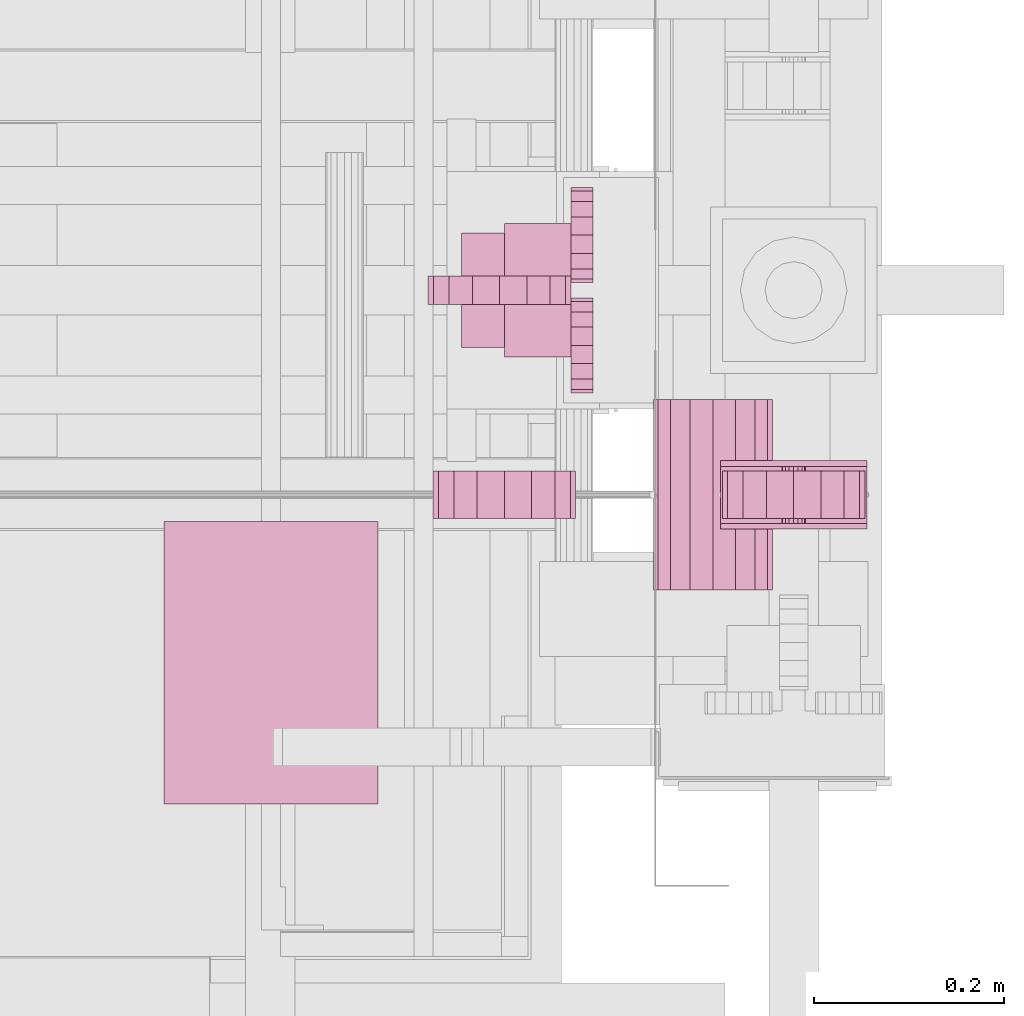
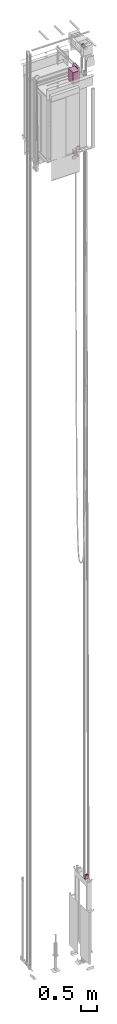
# One storey, part 11 of 13: 7 transport elements.
"""IFC4 building model written with IfcOpenShell, lengths in millimetres."""

from ifc_helpers import new_model, entity, si_unit, converted_unit, frame, origin_with_axes, place, context, subcontext, project, spatial, faceted_brep, element, save


model = new_model("IFC4")

# Units and contexts
context_of_model = context(None, 3, precision=0.01, world=origin_with_axes())
sub_context_1 = subcontext(context_of_model, None, None, "MODEL_VIEW")
sub_context_2 = subcontext(context_of_model, None, None, "MODEL_VIEW")
sub_context_3 = subcontext(context_of_model, None, None, "MODEL_VIEW")
sub_context_4 = subcontext(context_of_model, None, None, "MODEL_VIEW")
sub_context_5 = subcontext(context_of_model, None, None, "MODEL_VIEW")
sub_context_6 = subcontext(context_of_model, None, None, "MODEL_VIEW")
sub_context_7 = subcontext(context_of_model, None, None, "MODEL_VIEW")
ifc_project = project(units=[converted_unit("PLANEANGLEUNIT", "degree", entity("IfcPlaneAngleMeasure", 0.017453292519943), si_unit("PLANEANGLEUNIT", "RADIAN"), dimensions=[0, 0, 0, 0, 0, 0, 0]), si_unit("LENGTHUNIT", "METRE", prefix="MILLI"), si_unit("MASSUNIT", "GRAM", prefix="KILO"), converted_unit("TIMEUNIT", "year", entity("IfcTimeMeasure", 31557600.0), si_unit("TIMEUNIT", "SECOND"), dimensions=[0, 0, 1, 0, 0, 0, 0]), si_unit("THERMODYNAMICTEMPERATUREUNIT", "DEGREE_CELSIUS"), si_unit("AREAUNIT", "SQUARE_METRE"), si_unit("FORCEUNIT", "NEWTON"), si_unit("VOLUMEUNIT", "CUBIC_METRE"), si_unit("PRESSUREUNIT", "PASCAL"), si_unit("SOLIDANGLEUNIT", "STERADIAN")], contexts=[context_of_model])

# Site, building, storey
site = spatial("IfcSite", under=ifc_project)
building = spatial("IfcBuilding", under=site, Name="Document")
placement = place(None, origin_with_axes())
storey_placement = place(placement, frame((0.0, 0.0, -26400.0), z_axis=(0.0, 0.0, 1.0), x_axis=(1.0, 0.0, 0.0)))
storey = spatial("IfcBuildingStorey", under=building, at=storey_placement, Name="Z -26400", Elevation=-26400.0)

# Transport elements
transport_element_1_placement = place(storey_placement, frame((1879.0, 810.0, 3329.0), z_axis=(0.0, 0.0, 1.0), x_axis=(-1.0, 0.0, 0.0)))
element("IfcTransportElement", 1, at=transport_element_1_placement, inside=storey, ObjectType="beam PV (5500)", PredefinedType="ELEVATOR", context=sub_context_1, shape_type="Brep", body=[
    faceted_brep([(77.0, 36.0, 70.0), (77.0, 30.0, 70.0), (77.0, 30.0, -74.0), (77.0, -30.0, -74.0), (77.0, -30.0, 70.0), (77.0, -36.0, 70.0), (77.0, -36.0, -80.0), (77.0, 36.0, -80.0), (-77.0, 36.0, -80.0), (-77.0, -36.0, -80.0), (-77.0, -36.0, 70.0), (-77.0, -30.0, 70.0), (-77.0, -30.0, -74.0), (-77.0, 30.0, -74.0), (-77.0, 30.0, 70.0), (-77.0, 36.0, 70.0)], [[[0, 1, 2, 3, 4, 5, 6, 7]], [[8, 9, 10, 11, 12, 13, 14, 15]], [[8, 15, 0, 7]], [[1, 14, 13, 2]], [[12, 11, 4, 3]], [[5, 10, 9, 6]], [[6, 9, 8, 7]], [[13, 12, 3, 2]], [[15, 14, 1, 0]], [[11, 10, 5, 4]]]),
])
transport_element_2_placement = place(storey_placement, frame((1879.0, 810.0, 3329.0), z_axis=(0.0, 0.0, -1.0), x_axis=(0.0, -1.0, 0.0)))
element("IfcTransportElement", 2, at=transport_element_2_placement, inside=storey, ObjectType="S5500 Belt PV50", PredefinedType="ELEVATOR", context=sub_context_2, shape_type="Brep", body=[
    faceted_brep([(-25.0, 8.8388671875, 8.8388671875), (-25.0, 4.7835693359375, 11.548583984375), (-25.0, 0.0, 12.5), (-25.0, -4.7835693359375, 11.548583984375), (-25.0, -8.8388671875, 8.8388671875), (-25.0, -11.5484619140625, 4.783447265625), (-25.0, -12.5, 0.0), (-25.0, -11.5484619140625, -4.783447265625), (-25.0, -8.8388671875, -8.8388671875), (-25.0, -4.7835693359375, -11.548583984375), (-25.0, 0.0, -12.5), (-25.0, 4.7835693359375, -11.548583984375), (-25.0, 8.8388671875, -8.8388671875), (-25.0, 11.5484619140625, -4.783447265625), (-25.0, 12.5, 0.0), (-25.0, 11.5484619140625, 4.783447265625), (-30.0, 11.5484619140625, 4.783447265625), (-30.0, 8.8388671875, 8.8388671875), (-30.0, 12.5, 0.0), (-30.0, 4.7835693359375, 11.548583984375), (-30.0, 11.5484619140625, -4.783447265625), (-30.0, 0.0, 12.5), (-30.0, 8.8388671875, -8.8388671875), (-30.0, 4.7835693359375, -11.548583984375), (-30.0, 0.0, -12.5), (-30.0, -4.7835693359375, -11.548583984375), (-30.0, -8.8388671875, -8.8388671875), (-30.0, -11.5484619140625, -4.783447265625), (-30.0, -12.5, 0.0), (-30.0, -11.5484619140625, 4.783447265625), (-30.0, -8.8388671875, 8.8388671875), (-30.0, -4.7835693359375, 11.548583984375)], [[[0, 1, 2, 3, 4, 5, 6, 7, 8, 9, 10, 11, 12, 13, 14, 15]], [[16, 17, 0, 15]], [[14, 18, 16, 15]], [[17, 19, 1, 0]], [[13, 20, 18, 14]], [[19, 21, 2, 1]], [[18, 20, 22, 23, 24, 25, 26, 27, 28, 29, 30, 31, 21, 19, 17, 16]], [[12, 22, 20, 13]], [[21, 31, 3, 2]], [[11, 23, 22, 12]], [[31, 30, 4, 3]], [[10, 24, 23, 11]], [[30, 29, 5, 4]], [[9, 25, 24, 10]], [[29, 28, 6, 5]], [[8, 26, 25, 9]], [[28, 27, 7, 6]], [[7, 27, 26, 8]]]),
    faceted_brep([(25.0, 53.032958984375, 53.032958984375), (25.0, 28.7012939453125, 69.291015625), (25.0, 0.0, 75.0), (25.0, -28.7012939453125, 69.291015625), (25.0, -53.032958984375, 53.032958984375), (25.0, -69.291015625, 28.701171875), (25.0, -75.0, 0.0), (25.0, -69.291015625, -28.701171875), (25.0, -53.032958984375, -53.032958984375), (25.0, -28.7012939453125, -69.291015625), (25.0, 0.0, -75.0), (25.0, 28.7012939453125, -69.291015625), (25.0, 53.032958984375, -53.032958984375), (25.0, 69.291015625, -28.701171875), (25.0, 75.0, 0.0), (25.0, 69.291015625, 28.701171875), (-25.0, 69.291015625, 28.701171875), (-25.0, 53.032958984375, 53.032958984375), (-25.0, 75.0, 0.0), (-25.0, 28.7012939453125, 69.291015625), (-25.0, 69.291015625, -28.701171875), (-25.0, 0.0, 75.0), (-25.0, 53.032958984375, -53.032958984375), (-25.0, 28.7012939453125, -69.291015625), (-25.0, 0.0, -75.0), (-25.0, -28.7012939453125, -69.291015625), (-25.0, -53.032958984375, -53.032958984375), (-25.0, -69.291015625, -28.701171875), (-25.0, -75.0, 0.0), (-25.0, -69.291015625, 28.701171875), (-25.0, -53.032958984375, 53.032958984375), (-25.0, -28.7012939453125, 69.291015625)], [[[0, 1, 2, 3, 4, 5, 6, 7, 8, 9, 10, 11, 12, 13, 14, 15]], [[16, 17, 0, 15]], [[14, 18, 16, 15]], [[17, 19, 1, 0]], [[13, 20, 18, 14]], [[19, 21, 2, 1]], [[18, 20, 22, 23, 24, 25, 26, 27, 28, 29, 30, 31, 21, 19, 17, 16]], [[12, 22, 20, 13]], [[21, 31, 3, 2]], [[11, 23, 22, 12]], [[31, 30, 4, 3]], [[10, 24, 23, 11]], [[30, 29, 5, 4]], [[9, 25, 24, 10]], [[29, 28, 6, 5]], [[8, 26, 25, 9]], [[28, 27, 7, 6]], [[7, 27, 26, 8]]]),
    faceted_brep([(30.0, 8.8388671875, 8.8388671875), (30.0, 4.7835693359375, 11.548583984375), (30.0, 0.0, 12.5), (30.0, -4.7835693359375, 11.548583984375), (30.0, -8.8388671875, 8.8388671875), (30.0, -11.5484619140625, 4.783447265625), (30.0, -12.5, 0.0), (30.0, -11.5484619140625, -4.783447265625), (30.0, -8.8388671875, -8.8388671875), (30.0, -4.7835693359375, -11.548583984375), (30.0, 0.0, -12.5), (30.0, 4.7835693359375, -11.548583984375), (30.0, 8.8388671875, -8.8388671875), (30.0, 11.5484619140625, -4.783447265625), (30.0, 12.5, 0.0), (30.0, 11.5484619140625, 4.783447265625), (25.0, 11.5484619140625, 4.783447265625), (25.0, 8.8388671875, 8.8388671875), (25.0, 12.5, 0.0), (25.0, 4.7835693359375, 11.548583984375), (25.0, 11.5484619140625, -4.783447265625), (25.0, 0.0, 12.5), (25.0, 8.8388671875, -8.8388671875), (25.0, 4.7835693359375, -11.548583984375), (25.0, 0.0, -12.5), (25.0, -4.7835693359375, -11.548583984375), (25.0, -8.8388671875, -8.8388671875), (25.0, -11.5484619140625, -4.783447265625), (25.0, -12.5, 0.0), (25.0, -11.5484619140625, 4.783447265625), (25.0, -8.8388671875, 8.8388671875), (25.0, -4.7835693359375, 11.548583984375)], [[[0, 1, 2, 3, 4, 5, 6, 7, 8, 9, 10, 11, 12, 13, 14, 15]], [[16, 17, 0, 15]], [[14, 18, 16, 15]], [[17, 19, 1, 0]], [[13, 20, 18, 14]], [[19, 21, 2, 1]], [[18, 20, 22, 23, 24, 25, 26, 27, 28, 29, 30, 31, 21, 19, 17, 16]], [[12, 22, 20, 13]], [[21, 31, 3, 2]], [[11, 23, 22, 12]], [[31, 30, 4, 3]], [[10, 24, 23, 11]], [[30, 29, 5, 4]], [[9, 25, 24, 10]], [[29, 28, 6, 5]], [[8, 26, 25, 9]], [[28, 27, 7, 6]], [[7, 27, 26, 8]]]),
])
transport_element_3_placement = place(storey_placement, frame((1645.0, 1025.0, 30670.0), z_axis=(0.0, 0.0, -1.0), x_axis=(0.0, 1.0, 0.0)))
element("IfcTransportElement", 3, at=transport_element_3_placement, inside=storey, ObjectType="Car Guide shoe Bottom", PredefinedType="ELEVATOR", context=sub_context_3, shape_type="Brep", body=[
    faceted_brep([(15.0, -75.0, 204.0), (15.0, -46.2987060546875, 209.708984375), (15.0, -21.967041015625, 225.966796875), (15.0, -5.708984375, 250.298828125), (15.0, 0.0, 279.0), (15.0, -5.708984375, 307.701171875), (15.0, -21.967041015625, 332.033203125), (15.0, -46.2987060546875, 348.291015625), (15.0, -75.0, 354.0), (15.0, -103.7012939453125, 348.291015625), (15.0, -128.032958984375, 332.033203125), (15.0, -144.291015625, 307.701171875), (15.0, -150.0, 279.0), (15.0, -144.291015625, 250.298828125), (15.0, -128.032958984375, 225.966796875), (15.0, -103.7012939453125, 209.708984375), (-15.0, -75.0, 204.0), (-15.0, -103.7012939453125, 209.708984375), (-15.0, -128.032958984375, 225.966796875), (-15.0, -144.291015625, 250.298828125), (-15.0, -150.0, 279.0), (-15.0, -144.291015625, 307.701171875), (-15.0, -128.032958984375, 332.033203125), (-15.0, -103.7012939453125, 348.291015625), (-15.0, -75.0, 354.0), (-15.0, -46.2987060546875, 348.291015625), (-15.0, -21.967041015625, 332.033203125), (-15.0, -5.708984375, 307.701171875), (-15.0, 0.0, 279.0), (-15.0, -5.708984375, 250.298828125), (-15.0, -21.967041015625, 225.966796875), (-15.0, -46.2987060546875, 209.708984375)], [[[0, 1, 2, 3, 4, 5, 6, 7, 8, 9, 10, 11, 12, 13, 14, 15]], [[16, 17, 18, 19, 20, 21, 22, 23, 24, 25, 26, 27, 28, 29, 30, 31]], [[0, 15, 17, 16]], [[15, 14, 18, 17]], [[14, 13, 19, 18]], [[13, 12, 20, 19]], [[12, 11, 21, 20]], [[11, 10, 22, 21]], [[10, 9, 23, 22]], [[9, 8, 24, 23]], [[8, 7, 25, 24]], [[7, 6, 26, 25]], [[6, 5, 27, 26]], [[5, 4, 28, 27]], [[4, 3, 29, 28]], [[3, 2, 30, 29]], [[2, 1, 31, 30]], [[1, 0, 16, 31]]]),
    faceted_brep([(-107.94000244140625, 0.0, 213.0), (-104.13397216796875, 0.0, 193.865234375), (-93.29534912109375, 0.0, 177.64453125), (-77.07415771484375, 0.0, 166.806640625), (-57.94000244140625, 0.0, 163.0), (-38.80584716796875, 0.0, 166.806640625), (-22.58465576171875, 0.0, 177.64453125), (-11.74603271484375, 0.0, 193.865234375), (-7.94000244140625, 0.0, 213.0), (-11.74603271484375, 0.0, 232.134765625), (-22.58465576171875, 0.0, 248.35546875), (-38.80584716796875, 0.0, 259.193359375), (-57.94000244140625, 0.0, 263.0), (-77.07415771484375, 0.0, 259.193359375), (-93.29534912109375, 0.0, 248.35546875), (-104.13397216796875, 0.0, 232.134765625), (-107.94000244140625, 23.0, 213.0), (-104.13397216796875, 23.0, 232.134765625), (-93.29534912109375, 23.0, 248.35546875), (-77.07415771484375, 23.0, 259.193359375), (-57.94000244140625, 23.0, 263.0), (-38.80584716796875, 23.0, 259.193359375), (-22.58465576171875, 23.0, 248.35546875), (-11.74603271484375, 23.0, 232.134765625), (-7.94000244140625, 23.0, 213.0), (-11.74603271484375, 23.0, 193.865234375), (-22.58465576171875, 23.0, 177.64453125), (-38.80584716796875, 23.0, 166.806640625), (-57.94000244140625, 23.0, 163.0), (-77.07415771484375, 23.0, 166.806640625), (-93.29534912109375, 23.0, 177.64453125), (-104.13397216796875, 23.0, 193.865234375)], [[[0, 1, 2, 3, 4, 5, 6, 7, 8, 9, 10, 11, 12, 13, 14, 15]], [[16, 17, 18, 19, 20, 21, 22, 23, 24, 25, 26, 27, 28, 29, 30, 31]], [[0, 15, 17, 16]], [[15, 14, 18, 17]], [[14, 13, 19, 18]], [[13, 12, 20, 19]], [[12, 11, 21, 20]], [[11, 10, 22, 21]], [[10, 9, 23, 22]], [[9, 8, 24, 23]], [[8, 7, 25, 24]], [[7, 6, 26, 25]], [[6, 5, 27, 26]], [[5, 4, 28, 27]], [[4, 3, 29, 28]], [[3, 2, 30, 29]], [[2, 1, 31, 30]], [[1, 0, 16, 31]]]),
    faceted_brep([(7.93994140625, 23.0, 213.0), (11.7459716796875, 23.0, 232.134765625), (22.584716796875, 23.0, 248.35546875), (38.8057861328125, 23.0, 259.193359375), (57.93994140625, 23.0, 263.0), (77.07421875, 23.0, 259.193359375), (93.2952880859375, 23.0, 248.35546875), (104.134033203125, 23.0, 232.134765625), (107.93994140625, 23.0, 213.0), (104.134033203125, 23.0, 193.865234375), (93.2952880859375, 23.0, 177.64453125), (77.07421875, 23.0, 166.806640625), (57.93994140625, 23.0, 163.0), (38.8057861328125, 23.0, 166.806640625), (22.584716796875, 23.0, 177.64453125), (11.7459716796875, 23.0, 193.865234375), (7.93994140625, 0.0, 213.0), (11.7459716796875, 0.0, 193.865234375), (22.584716796875, 0.0, 177.64453125), (38.8057861328125, 0.0, 166.806640625), (57.93994140625, 0.0, 163.0), (77.07421875, 0.0, 166.806640625), (93.2952880859375, 0.0, 177.64453125), (104.134033203125, 0.0, 193.865234375), (107.93994140625, 0.0, 213.0), (104.134033203125, 0.0, 232.134765625), (93.2952880859375, 0.0, 248.35546875), (77.07421875, 0.0, 259.193359375), (57.93994140625, 0.0, 263.0), (38.8057861328125, 0.0, 259.193359375), (22.584716796875, 0.0, 248.35546875), (11.7459716796875, 0.0, 232.134765625)], [[[0, 1, 2, 3, 4, 5, 6, 7, 8, 9, 10, 11, 12, 13, 14, 15]], [[16, 17, 18, 19, 20, 21, 22, 23, 24, 25, 26, 27, 28, 29, 30, 31]], [[0, 15, 17, 16]], [[15, 14, 18, 17]], [[14, 13, 19, 18]], [[13, 12, 20, 19]], [[12, 11, 21, 20]], [[11, 10, 22, 21]], [[10, 9, 23, 22]], [[9, 8, 24, 23]], [[8, 7, 25, 24]], [[7, 6, 26, 25]], [[6, 5, 27, 26]], [[5, 4, 28, 27]], [[4, 3, 29, 28]], [[3, 2, 30, 29]], [[2, 1, 31, 30]], [[1, 0, 16, 31]]]),
    faceted_brep([(-60.0, -15.0, 0.0), (-60.0, -115.0, 0.0), (-60.0, -115.0, 145.0), (-60.0, -15.0, 145.0), (60.0, -15.0, 0.0), (60.0, -15.0, 145.0), (60.0, -115.0, 145.0), (60.0, -115.0, 0.0)], [[[0, 1, 2, 3]], [[4, 5, 6, 7]], [[0, 3, 5, 4]], [[3, 2, 6, 5]], [[2, 1, 7, 6]], [[1, 0, 4, 7]]]),
    faceted_brep([(-70.0, -70.0, 145.0), (70.0, -70.0, 145.0), (70.0, -70.0, 155.0), (-70.0, -70.0, 155.0), (12.0, -46.0, 155.0), (12.0, -46.0, 145.0), (-12.0, -46.0, 145.0), (-12.0, -46.0, 155.0), (-12.0, 20.0, 155.0), (-12.0, 20.0, 145.0), (-70.0, 20.0, 145.0), (-70.0, 20.0, 155.0), (70.0, 20.0, 155.0), (70.0, 20.0, 145.0), (12.0, 20.0, 145.0), (12.0, 20.0, 155.0)], [[[0, 1, 2, 3]], [[4, 5, 6, 7]], [[8, 9, 10, 11]], [[12, 13, 14, 15]], [[11, 10, 0, 3]], [[6, 9, 8, 7]], [[15, 14, 5, 4]], [[1, 13, 12, 2]], [[3, 2, 12, 15, 4, 7, 8, 11]], [[10, 9, 6, 5, 14, 13, 1, 0]]]),
])
transport_element_4_placement = place(storey_placement, frame((1645.0, 1025.0, 33729.0), z_axis=(0.0, 0.0, 1.0), x_axis=(0.0, -1.0, 0.0)))
element("IfcTransportElement", 4, at=transport_element_4_placement, inside=storey, ObjectType="Car Guide shoe Top", PredefinedType="ELEVATOR", context=sub_context_4, shape_type="Brep", body=[
    faceted_brep([(15.0, -75.0, 59.0), (15.0, -46.2987060546875, 64.7109375), (15.0, -21.967041015625, 80.96875), (15.0, -5.708984375, 105.296875), (15.0, 0.0, 134.0), (15.0, -5.708984375, 162.703125), (15.0, -21.967041015625, 187.03125), (15.0, -46.2987060546875, 203.2890625), (15.0, -75.0, 209.0), (15.0, -103.7012939453125, 203.2890625), (15.0, -128.032958984375, 187.03125), (15.0, -144.291015625, 162.703125), (15.0, -150.0, 134.0), (15.0, -144.291015625, 105.296875), (15.0, -128.032958984375, 80.96875), (15.0, -103.7012939453125, 64.7109375), (-15.0, -75.0, 59.0), (-15.0, -103.7012939453125, 64.7109375), (-15.0, -128.032958984375, 80.96875), (-15.0, -144.291015625, 105.296875), (-15.0, -150.0, 134.0), (-15.0, -144.291015625, 162.703125), (-15.0, -128.032958984375, 187.03125), (-15.0, -103.7012939453125, 203.2890625), (-15.0, -75.0, 209.0), (-15.0, -46.2987060546875, 203.2890625), (-15.0, -21.967041015625, 187.03125), (-15.0, -5.708984375, 162.703125), (-15.0, 0.0, 134.0), (-15.0, -5.708984375, 105.296875), (-15.0, -21.967041015625, 80.96875), (-15.0, -46.2987060546875, 64.7109375)], [[[0, 1, 2, 3, 4, 5, 6, 7, 8, 9, 10, 11, 12, 13, 14, 15]], [[16, 17, 18, 19, 20, 21, 22, 23, 24, 25, 26, 27, 28, 29, 30, 31]], [[0, 15, 17, 16]], [[15, 14, 18, 17]], [[14, 13, 19, 18]], [[13, 12, 20, 19]], [[12, 11, 21, 20]], [[11, 10, 22, 21]], [[10, 9, 23, 22]], [[9, 8, 24, 23]], [[8, 7, 25, 24]], [[7, 6, 26, 25]], [[6, 5, 27, 26]], [[5, 4, 28, 27]], [[4, 3, 29, 28]], [[3, 2, 30, 29]], [[2, 1, 31, 30]], [[1, 0, 16, 31]]]),
    faceted_brep([(-107.93994140625, 0.0, 68.0), (-104.134033203125, 0.0, 48.8671875), (-93.2952880859375, 0.0, 32.64453125), (-77.07421875, 0.0, 21.8046875), (-57.93994140625, 0.0, 18.0), (-38.8057861328125, 0.0, 21.8046875), (-22.584716796875, 0.0, 32.64453125), (-11.7459716796875, 0.0, 48.8671875), (-7.93994140625, 0.0, 68.0), (-11.7459716796875, 0.0, 87.1328125), (-22.584716796875, 0.0, 103.35546875), (-38.8057861328125, 0.0, 114.1953125), (-57.93994140625, 0.0, 118.0), (-77.07421875, 0.0, 114.1953125), (-93.2952880859375, 0.0, 103.35546875), (-104.134033203125, 0.0, 87.1328125), (-107.93994140625, 23.0, 68.0), (-104.134033203125, 23.0, 87.1328125), (-93.2952880859375, 23.0, 103.35546875), (-77.07421875, 23.0, 114.1953125), (-57.93994140625, 23.0, 118.0), (-38.8057861328125, 23.0, 114.1953125), (-22.584716796875, 23.0, 103.35546875), (-11.7459716796875, 23.0, 87.1328125), (-7.93994140625, 23.0, 68.0), (-11.7459716796875, 23.0, 48.8671875), (-22.584716796875, 23.0, 32.64453125), (-38.8057861328125, 23.0, 21.8046875), (-57.93994140625, 23.0, 18.0), (-77.07421875, 23.0, 21.8046875), (-93.2952880859375, 23.0, 32.64453125), (-104.134033203125, 23.0, 48.8671875)], [[[0, 1, 2, 3, 4, 5, 6, 7, 8, 9, 10, 11, 12, 13, 14, 15]], [[16, 17, 18, 19, 20, 21, 22, 23, 24, 25, 26, 27, 28, 29, 30, 31]], [[0, 15, 17, 16]], [[15, 14, 18, 17]], [[14, 13, 19, 18]], [[13, 12, 20, 19]], [[12, 11, 21, 20]], [[11, 10, 22, 21]], [[10, 9, 23, 22]], [[9, 8, 24, 23]], [[8, 7, 25, 24]], [[7, 6, 26, 25]], [[6, 5, 27, 26]], [[5, 4, 28, 27]], [[4, 3, 29, 28]], [[3, 2, 30, 29]], [[2, 1, 31, 30]], [[1, 0, 16, 31]]]),
    faceted_brep([(70.0, -70.0, 10.0), (-70.0, -70.0, 10.0), (-70.0, -70.0, 0.0), (70.0, -70.0, 0.0), (-12.0, -46.0, 0.0), (-12.0, -46.0, 10.0), (12.0, -46.0, 10.0), (12.0, -46.0, 0.0), (12.0, 20.0, 0.0), (12.0, 20.0, 10.0), (70.0, 20.0, 10.0), (70.0, 20.0, 0.0), (-70.0, 20.0, 0.0), (-70.0, 20.0, 10.0), (-12.0, 20.0, 10.0), (-12.0, 20.0, 0.0)], [[[0, 1, 2, 3]], [[4, 5, 6, 7]], [[8, 9, 10, 11]], [[12, 13, 14, 15]], [[11, 10, 0, 3]], [[6, 9, 8, 7]], [[15, 14, 5, 4]], [[1, 13, 12, 2]], [[2, 12, 15, 4, 7, 8, 11, 3]], [[0, 10, 9, 6, 5, 14, 13, 1]]]),
    faceted_brep([(7.94000244140625, 23.0, 68.0), (11.74603271484375, 23.0, 87.1328125), (22.58465576171875, 23.0, 103.35546875), (38.80584716796875, 23.0, 114.1953125), (57.94000244140625, 23.0, 118.0), (77.07415771484375, 23.0, 114.1953125), (93.29534912109375, 23.0, 103.35546875), (104.13397216796875, 23.0, 87.1328125), (107.94000244140625, 23.0, 68.0), (104.13397216796875, 23.0, 48.8671875), (93.29534912109375, 23.0, 32.64453125), (77.07415771484375, 23.0, 21.8046875), (57.94000244140625, 23.0, 18.0), (38.80584716796875, 23.0, 21.8046875), (22.58465576171875, 23.0, 32.64453125), (11.74603271484375, 23.0, 48.8671875), (7.94000244140625, 0.0, 68.0), (11.74603271484375, 0.0, 48.8671875), (22.58465576171875, 0.0, 32.64453125), (38.80584716796875, 0.0, 21.8046875), (57.94000244140625, 0.0, 18.0), (77.07415771484375, 0.0, 21.8046875), (93.29534912109375, 0.0, 32.64453125), (104.13397216796875, 0.0, 48.8671875), (107.94000244140625, 0.0, 68.0), (104.13397216796875, 0.0, 87.1328125), (93.29534912109375, 0.0, 103.35546875), (77.07415771484375, 0.0, 114.1953125), (57.94000244140625, 0.0, 118.0), (38.80584716796875, 0.0, 114.1953125), (22.58465576171875, 0.0, 103.35546875), (11.74603271484375, 0.0, 87.1328125)], [[[0, 1, 2, 3, 4, 5, 6, 7, 8, 9, 10, 11, 12, 13, 14, 15]], [[16, 17, 18, 19, 20, 21, 22, 23, 24, 25, 26, 27, 28, 29, 30, 31]], [[0, 15, 17, 16]], [[15, 14, 18, 17]], [[14, 13, 19, 18]], [[13, 12, 20, 19]], [[12, 11, 21, 20]], [[11, 10, 22, 21]], [[10, 9, 23, 22]], [[9, 8, 24, 23]], [[8, 7, 25, 24]], [[7, 6, 26, 25]], [[6, 5, 27, 26]], [[5, 4, 28, 27]], [[4, 3, 29, 28]], [[3, 2, 30, 29]], [[2, 1, 31, 30]], [[1, 0, 16, 31]]]),
])
transport_element_5_placement = place(storey_placement, frame((1575.0, 810.0, 30872.0), z_axis=(0.0, 0.0, -1.0), x_axis=(0.0, 1.0, 0.0)))
element("IfcTransportElement", 5, at=transport_element_5_placement, inside=storey, ObjectType="S5500 below", PredefinedType="ELEVATOR", context=sub_context_5, shape_type="Brep", body=[
    faceted_brep([(-25.0, 0.0, 75.0), (-25.0, 28.7012939453125, 69.291015625), (-25.0, 53.032958984375, 53.033203125), (-25.0, 69.291015625, 28.701171875), (-25.0, 75.0, 0.0), (-25.0, 69.291015625, -28.701171875), (-25.0, 53.032958984375, -53.033203125), (-25.0, 28.7012939453125, -69.291015625), (-25.0, 0.0, -75.0), (-25.0, -28.7012939453125, -69.291015625), (-25.0, -53.032958984375, -53.033203125), (-25.0, -69.291015625, -28.701171875), (-25.0, -75.0, 0.0), (-25.0, -69.291015625, 28.701171875), (-25.0, -53.032958984375, 53.033203125), (-25.0, -28.7012939453125, 69.291015625), (25.0, 0.0, 75.0), (25.0, -28.7012939453125, 69.291015625), (25.0, -53.032958984375, 53.033203125), (25.0, -69.291015625, 28.701171875), (25.0, -75.0, 0.0), (25.0, -69.291015625, -28.701171875), (25.0, -53.032958984375, -53.033203125), (25.0, -28.7012939453125, -69.291015625), (25.0, 0.0, -75.0), (25.0, 28.7012939453125, -69.291015625), (25.0, 53.032958984375, -53.033203125), (25.0, 69.291015625, -28.701171875), (25.0, 75.0, 0.0), (25.0, 69.291015625, 28.701171875), (25.0, 53.032958984375, 53.033203125), (25.0, 28.7012939453125, 69.291015625)], [[[0, 1, 2, 3, 4, 5, 6, 7, 8, 9, 10, 11, 12, 13, 14, 15]], [[16, 17, 18, 19, 20, 21, 22, 23, 24, 25, 26, 27, 28, 29, 30, 31]], [[0, 15, 17, 16]], [[15, 14, 18, 17]], [[14, 13, 19, 18]], [[13, 12, 20, 19]], [[12, 11, 21, 20]], [[11, 10, 22, 21]], [[10, 9, 23, 22]], [[9, 8, 24, 23]], [[8, 7, 25, 24]], [[7, 6, 26, 25]], [[6, 5, 27, 26]], [[5, 4, 28, 27]], [[4, 3, 29, 28]], [[3, 2, 30, 29]], [[2, 1, 31, 30]], [[1, 0, 16, 31]]]),
])
transport_element_6_placement = place(storey_placement, frame((1330.0, 485.0, 33569.0), z_axis=(0.0, 0.0, 1.0), x_axis=(1.0, 0.0, 0.0)))
element("IfcTransportElement", 6, at=transport_element_6_placement, inside=storey, PredefinedType="ELEVATOR", context=sub_context_6, shape_type="Brep", body=[
    faceted_brep([(112.5, 0.0, 0.0), (112.5, 297.0, 0.0), (112.5, 297.0, 450.0), (112.5, 0.0, 450.0), (-112.5, 0.0, 0.0), (-112.5, 0.0, 450.0), (-112.5, 297.0, 450.0), (-112.5, 297.0, 0.0)], [[[0, 1, 2, 3]], [[4, 5, 6, 7]], [[0, 3, 5, 4]], [[3, 2, 6, 5]], [[2, 1, 7, 6]], [[1, 0, 4, 7]]]),
])
transport_element_7_placement = place(storey_placement, frame((1794.0, 810.0, 34609.0), z_axis=(0.0, 0.0, -1.0), x_axis=(0.0, -1.0, 0.0)))
element("IfcTransportElement", 7, at=transport_element_7_placement, inside=storey, ObjectType="Traction", PredefinedType="ELEVATOR", context=sub_context_7, shape_type="Brep", body=[
    faceted_brep([(-100.0, 0.0, 62.5), (-100.0, 23.917724609375, 57.7421875), (-100.0, 44.1942138671875, 44.1953125), (-100.0, 57.742431640625, 23.91796875), (-100.0, 62.5, 0.0), (-100.0, 57.742431640625, -23.91796875), (-100.0, 44.1942138671875, -44.1953125), (-100.0, 23.917724609375, -57.7421875), (-100.0, 0.0, -62.5), (-100.0, -23.917724609375, -57.7421875), (-100.0, -44.1942138671875, -44.1953125), (-100.0, -57.742431640625, -23.91796875), (-100.0, -62.5, 0.0), (-100.0, -57.742431640625, 23.91796875), (-100.0, -44.1942138671875, 44.1953125), (-100.0, -23.917724609375, 57.7421875), (100.0, 0.0, 62.5), (100.0, -23.917724609375, 57.7421875), (100.0, -44.1942138671875, 44.1953125), (100.0, -57.742431640625, 23.91796875), (100.0, -62.5, 0.0), (100.0, -57.742431640625, -23.91796875), (100.0, -44.1942138671875, -44.1953125), (100.0, -23.917724609375, -57.7421875), (100.0, 0.0, -62.5), (100.0, 23.917724609375, -57.7421875), (100.0, 44.1942138671875, -44.1953125), (100.0, 57.742431640625, -23.91796875), (100.0, 62.5, 0.0), (100.0, 57.742431640625, 23.91796875), (100.0, 44.1942138671875, 44.1953125), (100.0, 23.917724609375, 57.7421875)], [[[0, 1, 2, 3, 4, 5, 6, 7, 8, 9, 10, 11, 12, 13, 14, 15]], [[16, 17, 18, 19, 20, 21, 22, 23, 24, 25, 26, 27, 28, 29, 30, 31]], [[0, 15, 17, 16]], [[15, 14, 18, 17]], [[14, 13, 19, 18]], [[13, 12, 20, 19]], [[12, 11, 21, 20]], [[11, 10, 22, 21]], [[10, 9, 23, 22]], [[9, 8, 24, 23]], [[8, 7, 25, 24]], [[7, 6, 26, 25]], [[6, 5, 27, 26]], [[5, 4, 28, 27]], [[4, 3, 29, 28]], [[3, 2, 30, 29]], [[2, 1, 31, 30]], [[1, 0, 16, 31]]]),
])

save(model, "model.ifc")
